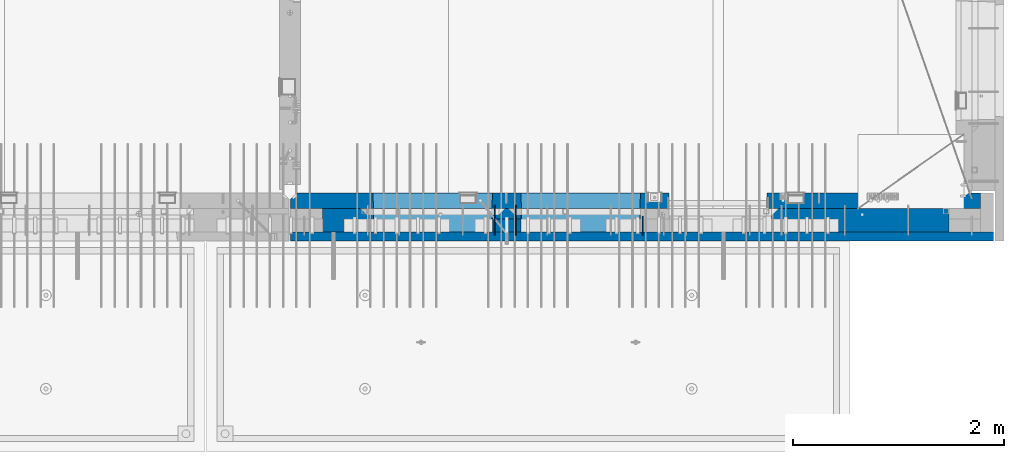
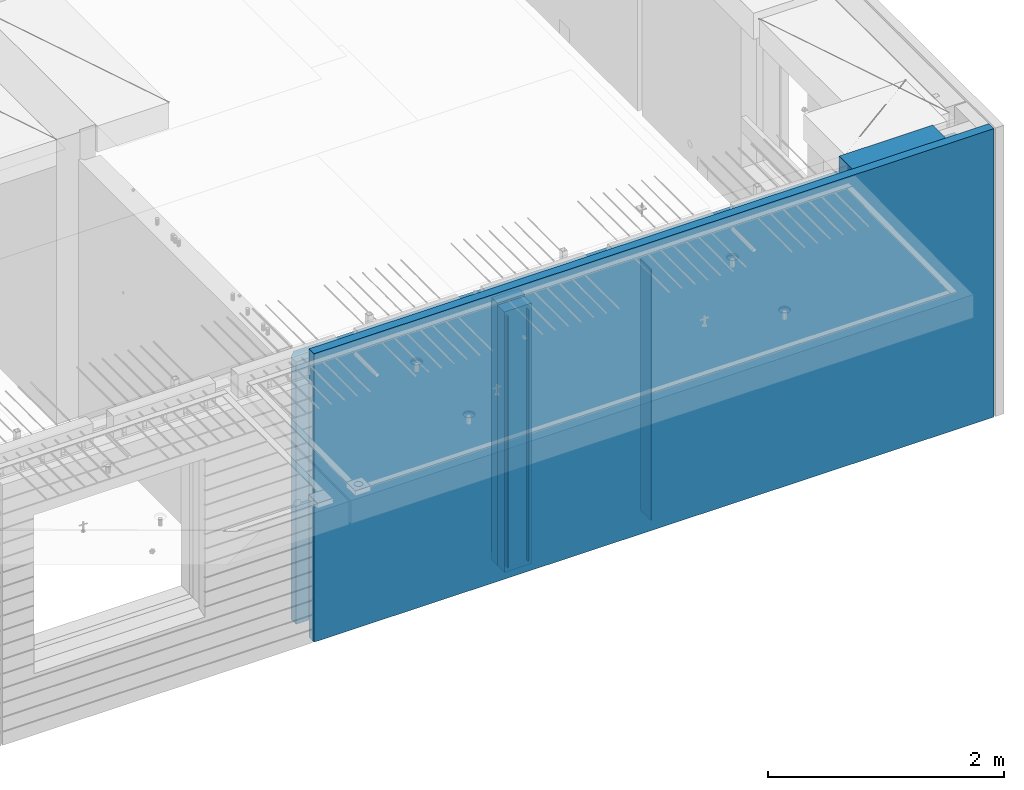
# One storey, part 223 of 334: 8 walls, 1 element without a shape of its own.
"""IFC2X3 building model written with IfcOpenShell, lengths in millimetres."""

from ifc_helpers import new_model, si_unit, frame, origin_with_axes, place, context, subcontext, project, spatial, faceted_brep, material, type_object, element, aggregate, save


model = new_model("IFC2X3")

# Units and contexts
model_context = context("Model", 3, precision=1e-05, world=origin_with_axes())
body_context = subcontext(model_context, "Body", "Model", "MODEL_VIEW")
ifc_project = project(units=[si_unit("LENGTHUNIT", "METRE", prefix="MILLI"), si_unit("AREAUNIT", "SQUARE_METRE"), si_unit("VOLUMEUNIT", "CUBIC_METRE"), si_unit("MASSUNIT", "GRAM", prefix="KILO"), si_unit("TIMEUNIT", "SECOND"), si_unit("PLANEANGLEUNIT", "RADIAN"), si_unit("SOLIDANGLEUNIT", "STERADIAN"), si_unit("THERMODYNAMICTEMPERATUREUNIT", "DEGREE_CELSIUS"), si_unit("LUMINOUSINTENSITYUNIT", "LUMEN")], contexts=[model_context])

# Site, building, storey
site_placement = place(None, origin_with_axes())
site = spatial("IfcSite", under=ifc_project, at=site_placement, CompositionType="ELEMENT")
building_placement = place(site_placement, origin_with_axes())
building = spatial("IfcBuilding", under=site, at=building_placement, CompositionType="ELEMENT")
storey_placement = place(building_placement, origin_with_axes())
storey = spatial("IfcBuildingStorey", under=building, at=storey_placement, Name="3", CompositionType="ELEMENT", Elevation=0.0)

# Assembly, walls
assembly_placement = place(storey_placement, origin_with_axes())
assembly = element("IfcElementAssembly", 1, at=assembly_placement, inside=storey, AssemblyPlace="NOTDEFINED", PredefinedType="REINFORCEMENT_UNIT")
ifc_material_1 = material(Name="Undefined")
wall_type_1 = type_object("IfcWallType", PredefinedType="NOTDEFINED")
wall_1_placement = place(assembly_placement, frame((31944.9998946285, 7780.0, 89115.0), z_axis=(0.0, 0.0, 1.0), x_axis=(0.0, -1.0, 0.0)))
wall_1 = element("IfcWall", 2, at=wall_1_placement, type_object=wall_type_1, material=ifc_material_1, Name="(PD)", context=body_context, shape_type="Brep", body=[
    faceted_brep([(0.0, 5.0, -1300.0), (0.0, 5.0, 1300.0), (180.0, 5.0, 1300.0), (180.0, 5.0, -1300.0), (0.0, -5.0, 1300.0), (180.0, -5.0, 1300.0), (0.0, -5.0, -1300.0), (180.0, -5.0, -1300.0)], [[[0, 1, 2, 3]], [[1, 4, 5, 2]], [[4, 6, 7, 5]], [[6, 0, 3, 7]], [[5, 7, 3, 2]], [[6, 4, 1, 0]]]),
])
wall_2_placement = place(assembly_placement, frame((30545.0021834468, 7880.0, 89115.0), z_axis=(0.0, 0.0, 1.0), x_axis=(0.0, -1.0, 0.0)))
wall_2 = element("IfcWall", 3, at=wall_2_placement, type_object=wall_type_1, material=ifc_material_1, Name="(PD)", context=body_context, shape_type="Brep", body=[
    faceted_brep([(0.0, 5.0, -1300.0), (0.0, 5.0, 1300.0), (280.0, 5.0, 1300.0), (280.0, 5.0, -1300.0), (0.0, -5.0, 1300.0), (280.0, -5.0, 1300.0), (0.0, -5.0, -1300.0), (280.0, -5.0, -1300.0)], [[[0, 1, 2, 3]], [[1, 4, 5, 2]], [[4, 6, 7, 5]], [[6, 0, 3, 7]], [[5, 7, 3, 2]], [[6, 4, 1, 0]]]),
])
wall_3_placement = place(assembly_placement, frame((30745.0021834468, 7880.0, 89115.0), z_axis=(0.0, 0.0, 1.0), x_axis=(0.0, -1.0, 0.0)))
wall_3 = element("IfcWall", 4, at=wall_3_placement, type_object=wall_type_1, material=ifc_material_1, Name="(PD)", context=body_context, shape_type="Brep", body=[
    faceted_brep([(0.0, 5.0, -1300.0), (0.0, 5.0, 1300.0), (280.0, 5.0, 1300.0), (280.0, 5.0, -1300.0), (0.0, -5.0, 1300.0), (280.0, -5.0, 1300.0), (0.0, -5.0, -1300.0), (280.0, -5.0, -1300.0)], [[[0, 1, 2, 3]], [[1, 4, 5, 2]], [[4, 6, 7, 5]], [[6, 0, 3, 7]], [[5, 7, 3, 2]], [[6, 4, 1, 0]]]),
])
ifc_material_2 = material(Name="COS5gt")
wall_type_2 = type_object("IfcWallType", PredefinedType="NOTDEFINED")
wall_4_placement = place(assembly_placement, frame((34845.0, 7740.0, 89247.5), z_axis=(0.0, 0.0, 1.0), x_axis=(-1.0, 3.00000001838171e-08, 0.0)))
wall_4 = element("IfcWall", 5, at=wall_4_placement, type_object=wall_type_2, material=ifc_material_2, context=body_context, shape_type="Brep", body=[
    faceted_brep([(917.0, -110.0, 1492.5), (917.0, -110.0, 1202.5), (917.0, 110.0, 1202.5), (917.0, 110.0, 1492.5), (0.0, 110.0, 1492.5), (0.0, -110.0, 1492.5), (0.0, -110.0, -1492.5), (1680.00110766775, -110.0, -1492.5), (1680.00110766775, -110.0, 857.5), (2649.99996185248, -110.0, 857.5), (2649.99996185248, -110.0, 1202.5), (0.0, 90.0, -1492.5), (1680.00110766775, 90.0, -1492.5), (0.0, 90.0, -1442.5), (1680.00110766775, 90.0, -1442.5), (0.0, 110.0, -1442.5), (1680.00110766775, 110.0, -1442.5), (1680.00110766775, 110.0, 857.5), (2649.99996185248, 110.0, 857.5), (2649.99996185248, -10.0, 857.5), (2649.99996185248, -10.0, 1202.5), (2649.99996185248, 110.0, 1202.5), (4049.99996185248, -10.0, 1202.5), (4049.99996185248, -10.0, -1492.5), (4049.99996185248, 90.0, -1492.5), (4049.99996185248, 90.0, -1442.5), (4049.99996185248, 110.0, -1442.5), (4049.99996185248, 110.0, 1202.5), (2920.0018706072, 110.0, 1202.5), (2920.0018706072, -10.0, 1202.5), (2920.0018706072, -110.0, 1202.5), (4049.99996185248, -110.0, 1202.5), (2920.0018706072, 110.0, -1442.5), (2920.0018706072, 90.0, -1442.5), (2920.0018706072, 90.0, -1492.5), (2920.0018706072, -10.0, -1492.5), (2920.0018706072, -110.0, -1492.5), (4045.94781655315, -110.0, -813.445945945947), (4040.0018706072, 110.0, -807.5), (4010.0018706072, 110.0, -807.5), (2960.0018706072, 110.0, -807.5), (2930.0018706072, 110.0, -807.5), (2924.05592466125, -110.0, -813.445945945947), (4049.99996185248, -110.0, -1492.5), (2924.05592466125, -110.0, 813.445945945947), (4045.94781655315, -110.0, 813.445945945947), (4040.0018706072, 110.0, -802.5), (4040.0018706072, 110.0, 807.5), (2930.0018706072, 110.0, 807.5), (2930.0018706072, 110.0, -802.5), (4320.0018706072, -10.0, 1202.5), (4320.0018706072, 110.0, 1202.5), (4320.0018706072, 110.0, -1442.5), (4320.0018706072, 90.0, -1442.5), (4320.0018706072, 90.0, -1492.5), (4320.0018706072, -10.0, -1492.5), (5928.5, 90.0, -1442.5), (5928.5, 90.0, -1492.5), (5928.5, 110.0, -1442.5), (5928.5, 110.0, -1492.5), (5930.0, -110.0, -1492.5), (5930.0, 110.0, -1492.5), (5930.0, 110.0, 1202.5), (5930.0, -110.0, 1202.5), (4320.0018706072, -110.0, -1492.5), (4320.0018706072, -110.0, 1202.5), (5445.94552773479, -110.0, -813.445945945947), (5439.99958178884, 110.0, -807.5), (5409.99958178884, 110.0, -807.5), (4359.99958178884, 110.0, -807.5), (4329.99958178884, 110.0, -807.5), (4324.05363584289, -110.0, -813.445945945947), (4324.05363584289, -110.0, 813.445945945947), (5445.94552773479, -110.0, 813.445945945947), (5439.99958178884, 110.0, -802.5), (5439.99958178884, 110.0, 807.5), (4329.99958178884, 110.0, 807.5), (4329.99958178884, 110.0, -802.5)], [[[0, 1, 2, 3]], [[4, 5, 0, 3]], [[1, 0, 5, 6, 7, 8, 9, 10]], [[6, 11, 12, 7]], [[11, 13, 14, 12]], [[11, 6, 5, 4, 15, 13]], [[13, 15, 16, 14]], [[7, 12, 14, 16, 17, 8]], [[8, 17, 18, 19, 9]], [[10, 9, 19, 20]], [[2, 1, 10, 20, 21]], [[17, 16, 15, 4, 3, 2, 21, 18]], [[20, 19, 18, 21]], [[22, 23, 24, 25, 26, 27]], [[28, 29, 30, 31, 22, 27]], [[29, 28, 32, 33, 34, 35]], [[30, 29, 35, 36]], [[37, 38, 39, 40, 41, 42]], [[43, 31, 30, 36], [37, 42, 44, 45]], [[46, 38, 37, 45, 47]], [[44, 48, 47, 45]], [[42, 41, 49, 48, 44]], [[32, 28, 27, 26], [41, 40, 39, 38, 46, 47, 48, 49]], [[33, 32, 26, 25]], [[34, 33, 25, 24]], [[34, 24, 23, 43, 36, 35]], [[31, 43, 23, 22]], [[50, 51, 52, 53, 54, 55]], [[56, 57, 54, 53]], [[58, 56, 53, 52]], [[57, 56, 58, 59]], [[60, 61, 62, 63]], [[54, 57, 59, 61, 60, 64, 55]], [[65, 50, 55, 64]], [[66, 67, 68, 69, 70, 71]], [[60, 63, 65, 64], [66, 71, 72, 73]], [[74, 67, 66, 73, 75]], [[72, 76, 75, 73]], [[71, 70, 77, 76, 72]], [[62, 61, 59, 58, 52, 51], [70, 69, 68, 67, 74, 75, 76, 77]], [[65, 63, 62, 51, 50]]]),
])
ifc_material_3 = material(Name="CONCRETE/C30/37")
wall_type_3 = type_object("IfcWallType", PredefinedType="NOTDEFINED")
wall_5_placement = place(assembly_placement, frame((35265.0, 7587.5, 89247.5), z_axis=(0.0, 0.0, 1.0), x_axis=(-1.0, 3.00000001838171e-08, 0.0)))
wall_5 = element("IfcWall", 6, at=wall_5_placement, type_object=wall_type_3, material=ifc_material_3, context=body_context, shape_type="Brep", body=[
    faceted_brep([(0.0, 42.5, -1492.5), (0.0, 42.5, 1492.5), (6650.0, 42.5, 1492.5), (6650.0, 42.5, -1492.5), (0.0, -42.5, 1492.5), (6650.0, -42.5, 1492.5), (0.0, -42.5, -1492.5), (6650.0, -42.5, -1492.5)], [[[0, 1, 2, 3]], [[1, 4, 5, 2]], [[4, 6, 7, 5]], [[6, 0, 3, 7]], [[5, 7, 3, 2]], [[6, 4, 1, 0]]]),
])
ifc_material_4 = material(Name="CONCRETE/C35/45")
wall_type_4 = type_object("IfcWallType", PredefinedType="NOTDEFINED")
wall_6_placement = place(assembly_placement, frame((35145.0, 7925.0, 89112.5), z_axis=(0.0, 0.0, 1.0), x_axis=(-1.0, 3.00000001838171e-08, 0.0)))
wall_6 = element("IfcWall", 7, at=wall_6_placement, type_object=wall_type_4, material=ifc_material_4, context=body_context, shape_type="Brep", body=[
    faceted_brep([(202.000000451517, -54.9999973486238, 1357.5), (202.000000451517, -54.9999973486238, -1357.5), (214.999999722531, -75.0, -1357.5), (214.999999722531, -75.0, 1357.5), (128.000000410604, -54.9999993903875, 1357.5), (128.000000410604, -54.9999993903875, -1357.5), (115.0, -75.0, 1357.5), (115.0, -75.0, -1357.5), (0.0, -75.0, -1357.5), (0.0, -75.0, 1357.5), (0.0, 75.0, 1357.5), (0.0, 75.0, -1357.5), (6470.0, -75.0, 1357.5), (6530.0, -15.0, 1357.5), (6530.0, 75.0, 1357.5), (6530.0, 75.0, -1357.5), (6530.0, -15.0, -1357.5), (6470.0, -75.0, -1357.5), (2950.00110766775, -75.0, -1357.5), (2946.15495382159, 75.0, -1357.5), (2950.00110766775, -75.0, 952.5), (2946.1549538216, 75.0, 948.653846153844), (2020.00110766775, -75.0, 952.5), (2023.8472615139, 75.0, 948.653846153844), (2020.00110766775, -75.0, -1357.5), (2023.8472615139, 75.0, -1357.5), (5749.99958178884, -75.0, -682.5), (5745.94552773479, 75.0, -678.445945945947), (4624.05363584289, 75.0, -678.445945945947), (4619.99958178884, -75.0, -682.5), (5749.99958178884, -75.0, 952.5), (5745.94552773479, 75.0, 948.445945945947), (4619.99958178884, -75.0, 952.5), (4624.05363584289, 75.0, 948.445945945947), (4345.94781655315, 75.0, -678.445945945947), (4345.94781655315, 75.0, 948.445945945947), (3224.05592466125, 75.0, 948.445945945947), (3224.05592466125, 75.0, -678.445945945947), (3220.0018706072, -75.0, -682.5), (3220.0018706072, -75.0, 952.5), (4350.0018706072, -75.0, -682.5), (4350.0018706072, -75.0, 952.5)], [[[0, 1, 2, 3]], [[4, 5, 1, 0]], [[6, 7, 5, 4]], [[8, 9, 10, 11]], [[0, 3, 12, 13, 14, 10, 9, 6, 4]], [[15, 14, 13, 16]], [[12, 17, 16, 13]], [[15, 16, 17, 18, 19]], [[19, 18, 20, 21]], [[22, 23, 21, 20]], [[24, 25, 23, 22]], [[26, 27, 28, 29]], [[27, 26, 30, 31]], [[32, 33, 31, 30]], [[29, 28, 33, 32]], [[11, 10, 14, 15, 19, 21, 23, 25], [34, 35, 36, 37], [27, 31, 33, 28]], [[38, 37, 36, 39]], [[40, 34, 37, 38]], [[34, 40, 41, 35]], [[39, 36, 35, 41]], [[24, 22, 20, 18, 17, 12, 3, 2], [40, 38, 39, 41], [26, 29, 32, 30]], [[8, 11, 25, 24, 2, 1, 5, 7]], [[9, 8, 7, 6]]]),
])
wall_type_5 = type_object("IfcWallType", PredefinedType="NOTDEFINED")
wall_7_placement = place(assembly_placement, frame((30795.0000381475, 7800.0, 89112.5), z_axis=(0.0, 0.0, 1.0), x_axis=(-1.0, 3.00000001838171e-08, 0.0)))
wall_7 = element("IfcWall", 8, at=wall_7_placement, type_object=wall_type_5, material=ifc_material_4, context=body_context, shape_type="Brep", body=[
    faceted_brep([(0.0, 50.0, -1357.5), (0.0, 50.0, 1357.5), (270.001908754726, 50.0, 1357.5), (270.001908754726, 50.0, -1357.5), (0.0, -50.0, 1357.5), (270.001908754726, -50.0, 1357.5), (0.0, -50.0, -1357.5), (270.001908754726, -50.0, -1357.5)], [[[0, 1, 2, 3]], [[1, 4, 5, 2]], [[4, 6, 7, 5]], [[6, 0, 3, 7]], [[5, 7, 3, 2]], [[6, 4, 1, 0]]]),
])
ifc_material_5 = material(Name="SPU")
wall_type_6 = type_object("IfcWallType", PredefinedType="NOTDEFINED")
wall_8_placement = place(assembly_placement, frame((30795.0000381475, 7690.0, 89102.5), z_axis=(0.0, 0.0, 1.0), x_axis=(-1.0, 3.00000001838171e-08, 0.0)))
wall_8 = element("IfcWall", 9, at=wall_8_placement, type_object=wall_type_6, material=ifc_material_5, context=body_context, shape_type="Brep", body=[
    faceted_brep([(0.0, 60.0, -1347.5), (0.0, 60.0, 1347.5), (270.001908754726, 60.0, 1347.5), (270.001908754726, 60.0, -1347.5), (0.0, -60.0, 1347.5), (270.001908754726, -60.0, 1347.5), (0.0, -60.0, -1347.5), (270.001908754726, -60.0, -1347.5)], [[[0, 1, 2, 3]], [[1, 4, 5, 2]], [[4, 6, 7, 5]], [[6, 0, 3, 7]], [[5, 7, 3, 2]], [[6, 4, 1, 0]]]),
])
aggregate(assembly, [wall_8, wall_7, wall_1, wall_2, wall_3, wall_6, wall_4, wall_5])

save(model, "model.ifc")
